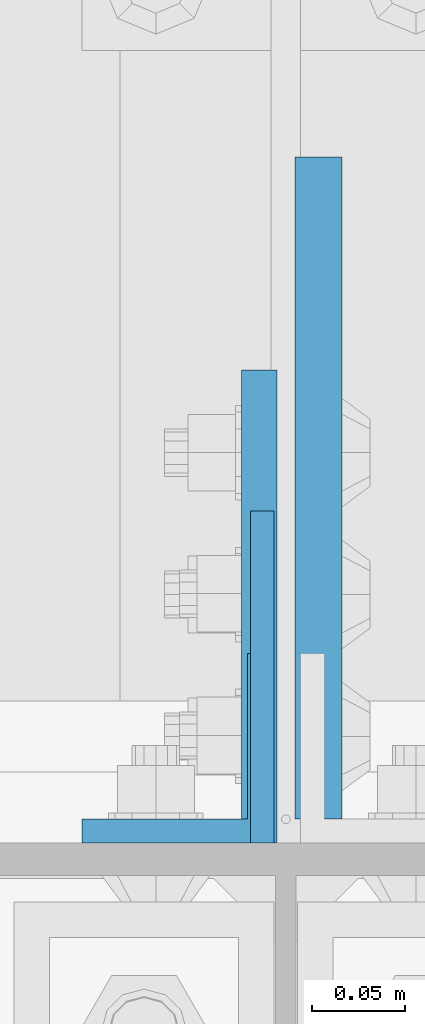
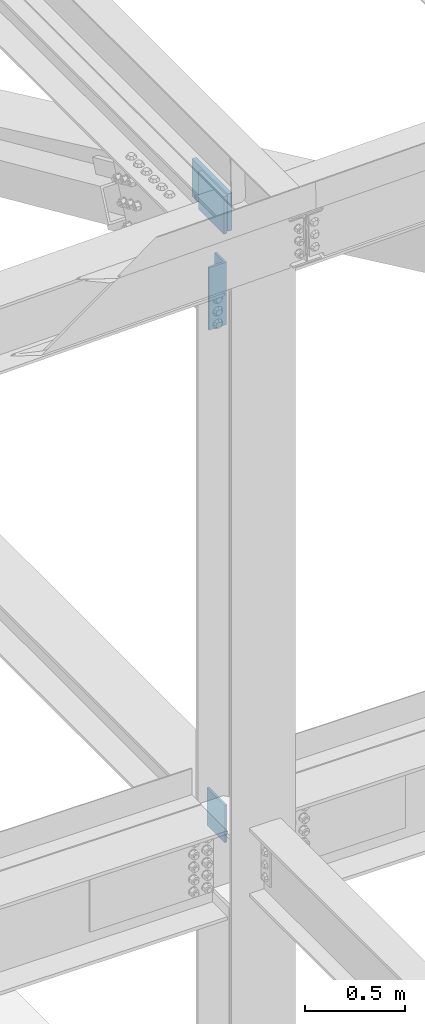
# One storey, part 1500 of 3843: 4 columns, 3 elements without a shape of their own.
"""IFC2X3 building model written with IfcOpenShell, lengths in millimetres."""

from ifc_helpers import new_model, si_unit, frame, origin_with_axes, place, context, subcontext, project, spatial, faceted_brep, material, type_object, element, aggregate, save


model = new_model("IFC2X3")

# Units and contexts
model_context = context("Model", 3, precision=1e-05, world=origin_with_axes())
body_context = subcontext(model_context, "Body", "Model", "MODEL_VIEW")
ifc_project = project(units=[si_unit("LENGTHUNIT", "METRE", prefix="MILLI"), si_unit("AREAUNIT", "SQUARE_METRE"), si_unit("VOLUMEUNIT", "CUBIC_METRE"), si_unit("MASSUNIT", "GRAM", prefix="KILO"), si_unit("TIMEUNIT", "SECOND"), si_unit("PLANEANGLEUNIT", "RADIAN"), si_unit("SOLIDANGLEUNIT", "STERADIAN"), si_unit("THERMODYNAMICTEMPERATUREUNIT", "DEGREE_CELSIUS"), si_unit("LUMINOUSINTENSITYUNIT", "LUMEN")], contexts=[model_context])

# Site, building, storey
site_placement = place(None, origin_with_axes())
site = spatial("IfcSite", under=ifc_project, at=site_placement, CompositionType="ELEMENT")
building_placement = place(site_placement, origin_with_axes())
building = spatial("IfcBuilding", under=site, at=building_placement, Name="Undefined", CompositionType="ELEMENT")
storey_placement = place(building_placement, origin_with_axes())
storey = spatial("IfcBuildingStorey", under=building, at=storey_placement, Name="Undefined", CompositionType="ELEMENT", Elevation=0.0)

# Assembly, column
assembly_1_placement = place(storey_placement, origin_with_axes())
assembly_1 = element("IfcElementAssembly", 1, at=assembly_1_placement, inside=storey, Name="COLUMN", AssemblyPlace="NOTDEFINED", PredefinedType="RIGID_FRAME")
ifc_material = material(Name="STEEL/A572-50")
column_type_1 = type_object("IfcColumnType", PredefinedType="NOTDEFINED")
column_1_placement = place(assembly_1_placement, frame((70243.7, 25882.8320000002, 42131.127980604), z_axis=(0.0, -1.0, 0.0), x_axis=(0.0, 0.0, 1.0)))
column_1 = element("IfcColumn", 2, at=column_1_placement, type_object=column_type_1, material=ifc_material, Name="PLATE", context=body_context, shape_type="Brep", body=[
    faceted_brep([(0.0, 6.35000000000582, -89.1319999999978), (0.0, 6.35000000000582, 89.1319999999978), (228.599999999999, 6.35000000000582, 89.1319999999978), (228.599999999999, 6.35000000000582, -89.1319999999978), (0.0, -6.35000000000582, 89.1319999999978), (228.599999999999, -6.35000000000582, 89.1319999999978), (0.0, -6.35000000000582, -89.1319999999978), (228.599999999999, -6.35000000000582, -89.1319999999978)], [[[0, 1, 2, 3]], [[1, 4, 5, 2]], [[4, 6, 7, 5]], [[6, 0, 3, 7]], [[5, 7, 3, 2]], [[6, 4, 1, 0]]]),
])

assembly_2_placement = place(storey_placement, origin_with_axes())
assembly_2 = element("IfcElementAssembly", 3, at=assembly_2_placement, inside=storey, Name="PLATE", AssemblyPlace="NOTDEFINED", PredefinedType="RIGID_FRAME")
column_type_2 = type_object("IfcColumnType", Name="L4X4X1/2", PredefinedType="NOTDEFINED")
column_2_placement = place(assembly_2_placement, frame((70197.6625, 25844.5000000153, 45281.9621849465), z_axis=(0.0, 1.0, 0.0), x_axis=(0.0, 0.0, 1.0)))
column_2 = element("IfcColumn", 4, at=column_2_placement, type_object=column_type_2, material=ifc_material, Name="ANGLE", ObjectType="L4X4X1/2", context=body_context, shape_type="Brep", body=[
    faceted_brep([(0.0, 50.8000000000029, -50.8000000000029), (0.0, 50.8000000000029, 50.8000000000029), (381.0, 50.8000000000029, 50.8000000000029), (381.0, 50.8000000000029, -50.8000000000029), (0.0, 38.0999999999985, 50.8000000000029), (381.0, 38.0999999999985, 50.8000000000029), (0.0, 38.0999999999985, -38.0999999999985), (381.0, 38.0999999999985, -38.1000000000058), (0.0, -50.8000000000029, -38.1000000000058), (381.0, -50.8000000000029, -38.1000000000058), (0.0, -50.8000000000029, -50.8000000000029), (381.0, -50.8000000000029, -50.8000000000029)], [[[0, 1, 2, 3]], [[1, 4, 5, 2]], [[4, 6, 7, 5]], [[6, 8, 9, 7]], [[8, 10, 11, 9]], [[10, 0, 3, 11]], [[5, 7, 9, 11, 3, 2]], [[10, 8, 6, 4, 1, 0]]]),
])
aggregate(assembly_2, [column_2])

# Column
column_type_3 = type_object("IfcColumnType", PredefinedType="NOTDEFINED")
column_3_placement = place(assembly_1_placement, frame((70242.1125, 25920.7, 45835.9996842842), z_axis=(0.0, -1.0, 0.0), x_axis=(0.0, 0.0, 1.0)))
column_3 = element("IfcColumn", 5, at=column_3_placement, type_object=column_type_3, material=ifc_material, Name="PLATE", context=body_context, shape_type="Brep", body=[
    faceted_brep([(0.0, 9.52499999999418, -127.0), (0.0, 9.52499999999418, 127.0), (228.599999999999, 9.52499999999418, 127.0), (228.599999999999, 9.52499999999418, -127.0), (0.0, -9.52499999999418, 127.0), (228.599999999999, -9.52499999999418, 127.0), (0.0, -9.52499999999418, -127.0), (228.599999999999, -9.52499999999418, -127.0)], [[[0, 1, 2, 3]], [[1, 4, 5, 2]], [[4, 6, 7, 5]], [[6, 0, 3, 7]], [[5, 7, 3, 2]], [[6, 4, 1, 0]]]),
])

aggregate(assembly_1, [column_1, column_3])

# Assembly, column
assembly_3_placement = place(storey_placement, origin_with_axes())
assembly_3 = element("IfcElementAssembly", 6, at=assembly_3_placement, inside=storey, Name="BEAM", AssemblyPlace="NOTDEFINED", PredefinedType="RIGID_FRAME")
column_type_4 = type_object("IfcColumnType", PredefinedType="NOTDEFINED")
column_4_placement = place(assembly_3_placement, frame((70273.8624999186, 25984.1998402014, 45835.9996842842), z_axis=(0.0, -1.0, 0.0), x_axis=(0.0, 0.0, 1.0)))
column_4 = element("IfcColumn", 7, at=column_4_placement, type_object=column_type_4, material=ifc_material, Name="PLATE", context=body_context, shape_type="Brep", body=[
    faceted_brep([(-1.45519152283669e-11, 12.7000000000025, -177.800000000003), (-1.45519152283669e-11, 12.7000000000025, 177.800000000003), (228.600000000013, 12.6999999999971, 177.799999999999), (228.600000000013, 12.6999999999971, -177.799999999999), (4.36557456851006e-11, -12.7000000000171, 177.800000000003), (228.600000000013, -12.6999999999971, 177.799999999999), (4.36557456851006e-11, -12.7000000000171, -177.800000000003), (228.600000000013, -12.6999999999971, -177.799999999999)], [[[0, 1, 2, 3]], [[1, 4, 5, 2]], [[4, 6, 7, 5]], [[6, 0, 3, 7]], [[5, 7, 3, 2]], [[6, 4, 1, 0]]]),
])
aggregate(assembly_3, [column_4])

save(model, "model.ifc")
